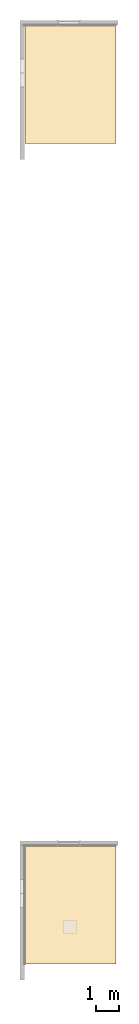
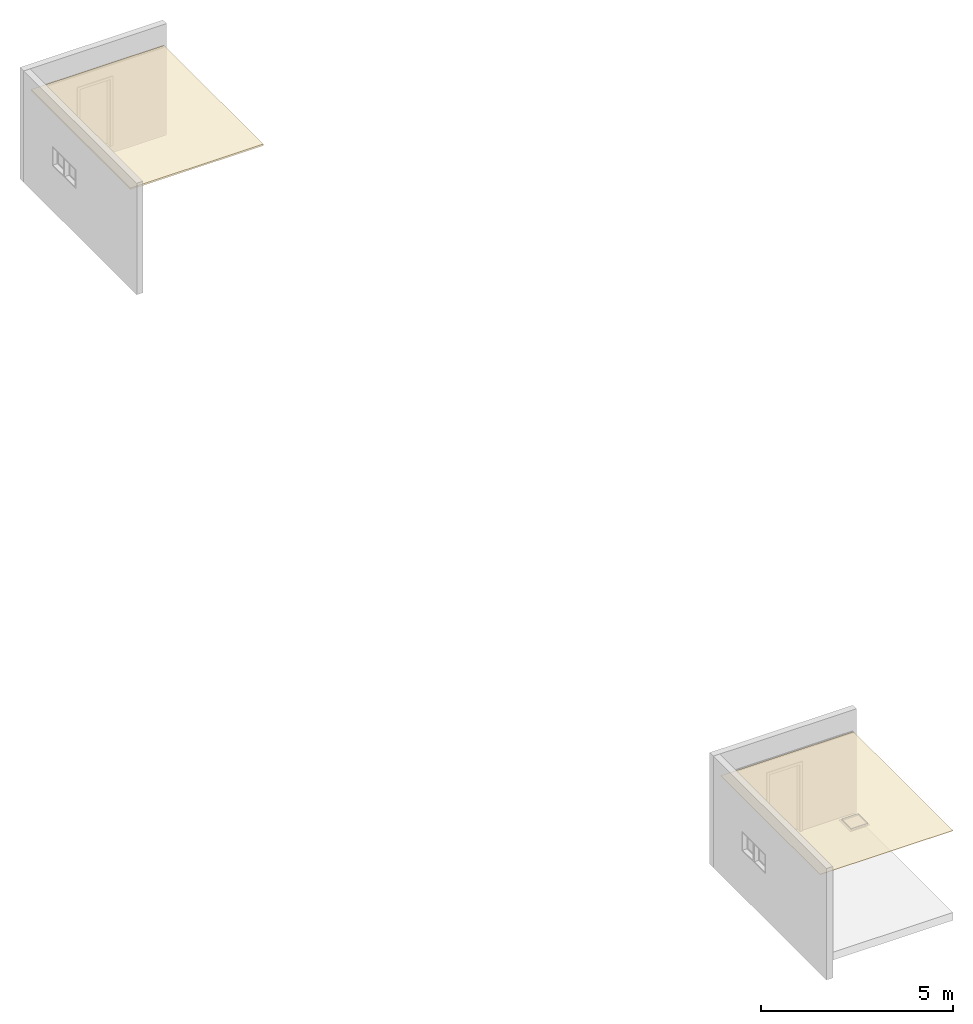
# One storey, part 3 of 5: 3 coverings.
"""IFC2X3 building model written with IfcOpenShell, lengths in millimetres."""

from ifc_helpers import new_model, entity, si_unit, converted_unit, derived_unit, direction, frame, frame_2d, origin, place, context, subcontext, project, spatial, polyline, rectangle, outline, extrude, material, layer, layer_set, layer_usage, type_object, element, save


model = new_model("IFC2X3")

# Units and contexts
model_context = context("Model", 3, precision=0.01, world=origin(), true_north=direction((6.12303176911189e-17, 1.0)))
body_context = subcontext(model_context, "Body", "Model", "MODEL_VIEW")
ifc_project = project(units=[si_unit("LENGTHUNIT", "METRE", prefix="MILLI"), si_unit("AREAUNIT", "SQUARE_METRE"), si_unit("VOLUMEUNIT", "CUBIC_METRE"), converted_unit("PLANEANGLEUNIT", "DEGREE", entity("IfcRatioMeasure", 0.0174532925199433), si_unit("PLANEANGLEUNIT", "RADIAN"), dimensions=[0, 0, 0, 0, 0, 0, 0]), si_unit("MASSUNIT", "GRAM", prefix="KILO"), derived_unit("MASSDENSITYUNIT", [(si_unit("MASSUNIT", "GRAM", prefix="KILO"), 1), (si_unit("LENGTHUNIT", "METRE"), -3)]), si_unit("TIMEUNIT", "SECOND"), si_unit("FREQUENCYUNIT", "HERTZ"), si_unit("THERMODYNAMICTEMPERATUREUNIT", "DEGREE_CELSIUS"), derived_unit("THERMALTRANSMITTANCEUNIT", [(si_unit("MASSUNIT", "GRAM", prefix="KILO"), 1), (si_unit("THERMODYNAMICTEMPERATUREUNIT", "KELVIN"), -1), (si_unit("TIMEUNIT", "SECOND"), -3)]), derived_unit("VOLUMETRICFLOWRATEUNIT", [(si_unit("LENGTHUNIT", "METRE"), 3), (si_unit("TIMEUNIT", "SECOND"), -1)]), si_unit("ELECTRICCURRENTUNIT", "AMPERE"), si_unit("ELECTRICVOLTAGEUNIT", "VOLT"), si_unit("POWERUNIT", "WATT"), si_unit("FORCEUNIT", "NEWTON", prefix="KILO"), si_unit("ILLUMINANCEUNIT", "LUX"), si_unit("LUMINOUSFLUXUNIT", "LUMEN"), si_unit("LUMINOUSINTENSITYUNIT", "CANDELA"), derived_unit("USERDEFINED", [(si_unit("MASSUNIT", "GRAM", prefix="KILO"), -1), (si_unit("LENGTHUNIT", "METRE"), -2), (si_unit("TIMEUNIT", "SECOND"), 3), (si_unit("LUMINOUSFLUXUNIT", "LUMEN"), 1)]), derived_unit("LINEARVELOCITYUNIT", [(si_unit("LENGTHUNIT", "METRE"), 1), (si_unit("TIMEUNIT", "SECOND"), -1)]), si_unit("PRESSUREUNIT", "PASCAL"), derived_unit("USERDEFINED", [(si_unit("LENGTHUNIT", "METRE"), -2), (si_unit("MASSUNIT", "GRAM", prefix="KILO"), 1), (si_unit("TIMEUNIT", "SECOND"), -2)])], contexts=[model_context])

# Site, building, storey
site_placement = place(None, origin())
site = spatial("IfcSite", under=ifc_project, at=site_placement, CompositionType="ELEMENT")
building_placement = place(site_placement, origin())
building = spatial("IfcBuilding", under=site, at=building_placement, CompositionType="ELEMENT")
storey_placement = place(building_placement, origin())
storey = spatial("IfcBuildingStorey", under=building, at=storey_placement, Name="Base Level", CompositionType="ELEMENT", Elevation=0.0)

# Coverings
ifc_material_1 = material(Name="ceiling Flush Plastered - 12mm")
ifc_layer_1 = layer(ifc_material_1, 11.0)
ifc_layer_set_1 = layer_set([ifc_layer_1])
ifc_layer_usage_1 = layer_usage(ifc_layer_set_1, "AXIS3", "POSITIVE", 0.0)
covering_type_1 = type_object("IfcCoveringType", PredefinedType="CEILING")
covering_1_placement = place(building_placement, origin())
element("IfcCovering", 1, at=covering_1_placement, inside=storey, type_object=covering_type_1, material=ifc_layer_usage_1, PredefinedType="CEILING", context=body_context, shape_type="SweptSolid", body=[
    extrude(outline(polyline([(-2592.50000000002, -2001.5), (2592.50000000002, -2001.5), (2592.50000000002, 2001.5), (-2592.50000000002, 2001.5), (-2592.50000000002, -2001.5)]), holes=[polyline([(729.470424730623, -282.61328137957), (729.470424730622, 228.086718620443), (1240.17042473062, 228.086718620443), (1240.17042473062, -282.61328137957), (729.470424730623, -282.61328137957)])]), frame((107465.234552934, 3605.41938039374, 2600.0), z_axis=(0.0, 0.0, 1.0), x_axis=(0.0, -1.0, 0.0)), (0.0, 0.0, 1.0), 11.0000000000002),
])
ifc_material_2 = material(Name="Ceiling Tile - Smooth Tile with 600 x 600(1)")
ifc_layer_2 = layer(ifc_material_2, 36.0)
ifc_material_3 = material(Name="Ceiling Tile - Smooth Tile with 600 x 600")
ifc_layer_3 = layer(ifc_material_3, 15.0)
ifc_layer_set_2 = layer_set([ifc_layer_2, ifc_layer_3])
ifc_layer_usage_2 = layer_usage(ifc_layer_set_2, "AXIS3", "POSITIVE", 0.0)
covering_type_2 = type_object("IfcCoveringType", PredefinedType="CEILING")
covering_2_placement = place(building_placement, origin())
element("IfcCovering", 2, at=covering_2_placement, inside=storey, type_object=covering_type_2, material=ifc_layer_usage_2, PredefinedType="CEILING", context=body_context, shape_type="SweptSolid", body=[
    extrude(rectangle(XDim=4007.00000000001, YDim=5184.00000000002, at=frame_2d((0.0, 2.04636307898909e-12), x_axis=(1.0, 0.0))), frame((107467.234552934, 39604.9193803937, 2600.0), z_axis=(0.0, 0.0, 1.0), x_axis=(-1.0, 0.0, 0.0)), (0.0, 0.0, 1.0), 50.9999999999998),
])
ifc_layer_4 = layer(ifc_material_3, 1.0)
ifc_layer_5 = layer(ifc_material_3, 15.0)
ifc_layer_set_3 = layer_set([ifc_layer_4, ifc_layer_5])
ifc_layer_usage_3 = layer_usage(ifc_layer_set_3, "AXIS3", "POSITIVE", 0.0)
covering_type_3 = type_object("IfcCoveringType", PredefinedType="CEILING")
covering_3_placement = place(building_placement, origin())
element("IfcCovering", 3, at=covering_3_placement, inside=storey, type_object=covering_type_3, material=ifc_layer_usage_3, PredefinedType="CEILING", context=body_context, shape_type="SweptSolid", body=[
    extrude(rectangle(XDim=4003.00000000001, YDim=5185.00000000005, at=frame_2d((0.0, 6.82121026329696e-13), x_axis=(1.0, 0.0))), frame((107465.234552934, 3605.41938039374, 2600.0), z_axis=(0.0, 0.0, 1.0), x_axis=(-1.0, 0.0, 0.0)), (0.0, 0.0, 1.0), 16.0000000000002),
])

save(model, "model.ifc")
